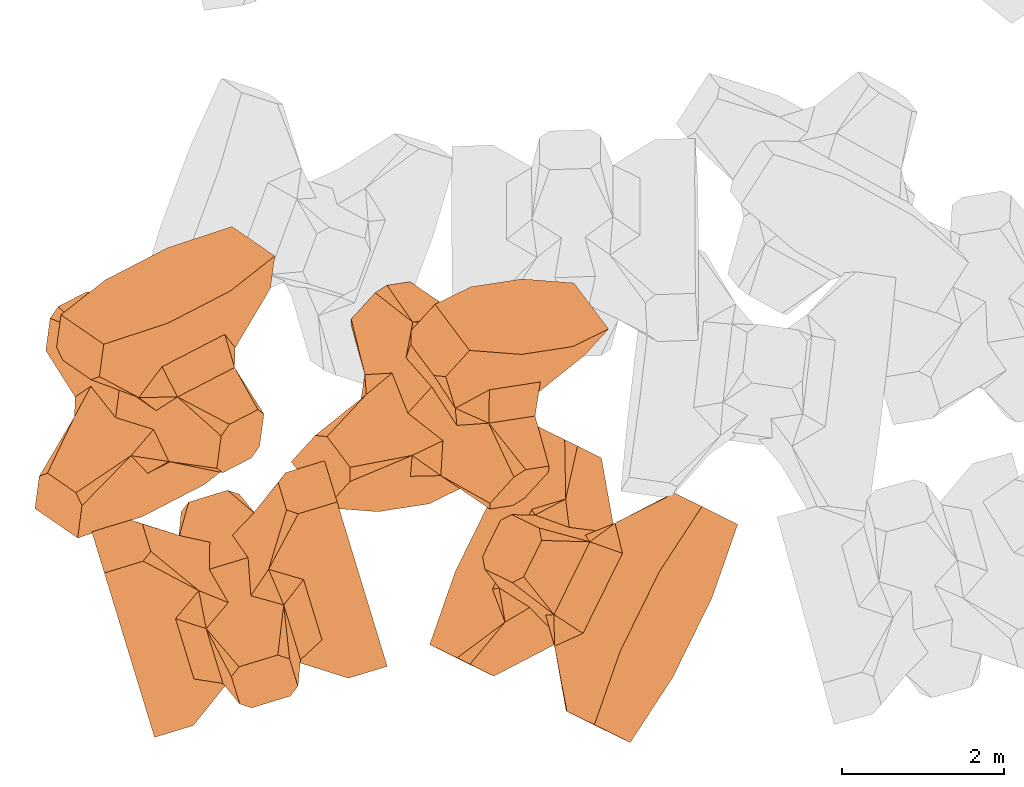
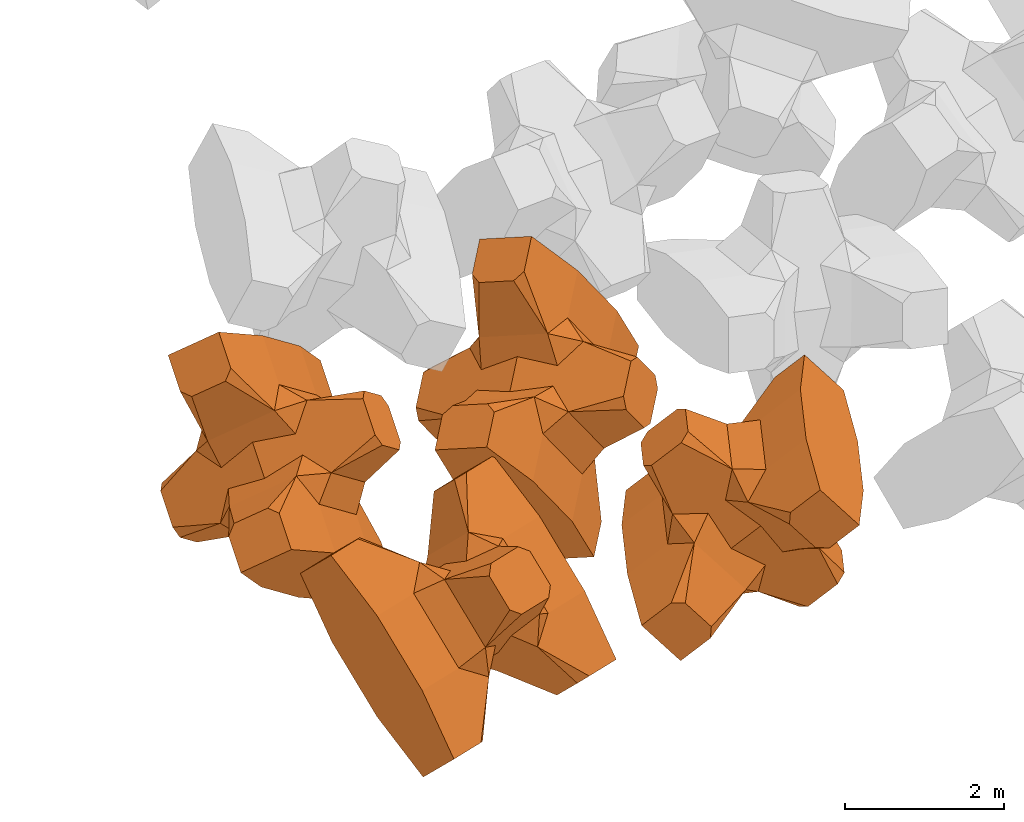
# One storey, part 1 of 17: 4 civil elements.
"""IFC4 building model written with IfcOpenShell, lengths in metres."""

from ifc_helpers import new_model, entity, si_unit, converted_unit, frame, origin_with_axes, origin_2d_with_axis, place, context, subcontext, project, spatial, polygons, element, save


model = new_model("IFC4")

# Units and contexts
model_context = context("Model", 3, precision=1e-05, world=origin_with_axes())
plan_context = context("Plan", 2, precision=1e-05, world=origin_2d_with_axis())
body_context = subcontext(model_context, "Body", "Model", "MODEL_VIEW")
ifc_project = project(units=[si_unit("VOLUMEUNIT", "CUBIC_METRE"), si_unit("LENGTHUNIT", "METRE"), converted_unit("PLANEANGLEUNIT", "degree", entity("IfcReal", 0.0174532925199433), si_unit("PLANEANGLEUNIT", "RADIAN"), dimensions=[0, 0, 0, 0, 0, 0, 0]), si_unit("AREAUNIT", "SQUARE_METRE")], contexts=[model_context, plan_context])

# Site, building, storey
site_placement = place(None, origin_with_axes())
site = spatial("IfcSite", under=ifc_project, at=site_placement)
building_placement = place(site_placement, origin_with_axes())
building = spatial("IfcBuilding", under=site, at=building_placement, Name="Building")
storey_placement = place(building_placement, origin_with_axes())
storey = spatial("IfcBuildingStorey", under=building, at=storey_placement, Name="Storey")

# Civil elements
civil_element_1_placement = place(storey_placement, frame((1.73069775104523, -20.6224308013916, 2.37295413017273), z_axis=(-0.206634434971923, 0.67694599384615, -0.706432114006351), x_axis=(-0.206210112575733, 0.675665398113698, 0.707780798880107)))
element("IfcCivilElement", 1, at=civil_element_1_placement, inside=storey, ObjectType="IfcCivilElementType", context=body_context, shape_type="Tessellation", body=[
    polygons([(0.50000011920929, 0.500000059604645, 0.821428656578064), (0.374999821186066, 0.249999940395355, 1.5), (0.550000011920929, 0.145680621266365, 0.550000071525574), (0.374999821186066, -0.250000029802322, 1.5), (0.651315808296204, -0.250000029802322, 1.45970545872842e-07), (0.651315808296204, 0.249999940395355, 1.45970545872842e-07), (0.550000011920929, -0.145680695772171, 0.550000071525574), (0.50000011920929, -0.500000059604645, 0.821428656578064), (-0.25, 0.374999791383743, 1.5), (0.249999970197678, 0.374999791383743, 1.5), (-0.500000059604645, 0.500000059604645, 0.821428656578064), (-0.550000011920929, 0.824999988079071, 0.550000071525574), (0.550000011920929, 0.824999988079071, 0.550000071525574), (-0.550000011920929, 1.5, 0.550000071525574), (0.550000011920929, 1.5, 0.550000071525574), (-0.25, -0.375, 1.5), (0.249999970197678, -0.375, 1.5), (-0.374999970197678, -0.250000029802322, 1.5), (-0.374999970197678, 0.249999940395355, 1.5), (1.5, 0.87499988079071, -0.249999806284904), (1.5, 0.87499988079071, 0.25000011920929), (0.845557510852814, 0.449999898672104, -0.495555102825165), (0.845557510852814, 0.449999898672104, 0.495555102825165), (1.5, 1.5, -0.374999791383743), (1.5, 1.5, 0.374999940395355), (1.5, 1.0, -0.374999791383743), (1.5, 1.0, 0.374999940395355), (-1.5, 1.5, -0.374999791383743), (-1.5, 1.5, 0.374999940395355), (-0.550000011920929, 1.5, -0.54999977350235), (0.550000011920929, 1.5, -0.54999977350235), (0.550000011920929, 0.145680621266365, -0.54999977350235), (-0.500000059604645, -0.500000059604645, 0.821428656578064), (-0.550000011920929, -0.145680695772171, 0.550000071525574), (-0.651315808296204, 0.249999940395355, 1.45970545872842e-07), (-0.651315808296204, -0.250000029802322, 1.45970545872842e-07), (-0.550000011920929, 0.145680621266365, 0.550000071525574), (-1.5, 0.87499988079071, 0.25000011920929), (-1.5, 0.87499988079071, -0.249999806284904), (-0.845557391643524, 0.449999898672104, 0.495555102825165), (-0.845557391643524, 0.449999898672104, -0.495555102825165), (-1.5, 1.0, 0.374999940395355), (-1.5, 1.0, -0.374999791383743), (-0.550000011920929, 0.145680621266365, -0.54999977350235), (0.550000011920929, -0.825000107288361, 0.550000071525574), (-0.550000011920929, -0.825000107288361, 0.550000071525574), (0.550000011920929, -1.5, 0.550000071525574), (-0.550000011920929, -1.5, 0.550000071525574), (1.5, -0.875000059604645, 0.25000011920929), (1.5, -0.875000059604645, -0.249999806284904), (0.845557510852814, -0.450000137090683, 0.495555102825165), (0.845557510852814, -0.450000137090683, -0.495555102825165), (1.5, -1.5, 0.374999940395355), (1.5, -1.5, -0.374999791383743), (1.5, -1.00000011920929, 0.374999940395355), (1.5, -1.00000011920929, -0.374999791383743), (0.550000011920929, -1.5, -0.54999977350235), (-0.550000011920929, -1.5, -0.54999977350235), (-1.5, -1.5, -0.374999791383743), (-1.5, -1.5, 0.374999940395355), (0.550000011920929, -0.145680695772171, -0.54999977350235), (-1.5, -0.875000059604645, -0.249999806284904), (-1.5, -0.875000059604645, 0.25000011920929), (-0.845557391643524, -0.450000137090683, -0.495555102825165), (-0.845557391643524, -0.450000137090683, 0.495555102825165), (-1.5, -1.00000011920929, -0.374999791383743), (-1.5, -1.00000011920929, 0.374999940395355), (-0.550000011920929, -0.145680695772171, -0.54999977350235), (0.50000011920929, -0.500000059604645, -0.821428418159485), (0.374999821186066, -0.250000029802322, -1.49999976158142), (0.374999821186066, 0.249999940395355, -1.49999976158142), (0.50000011920929, 0.500000059604645, -0.821428418159485), (0.249999970197678, 0.374999791383743, -1.49999976158142), (-0.25, 0.374999791383743, -1.49999976158142), (-0.500000059604645, 0.500000059604645, -0.821428418159485), (0.550000011920929, 0.824999988079071, -0.54999977350235), (-0.550000011920929, 0.824999988079071, -0.54999977350235), (0.249999970197678, -0.375, -1.49999976158142), (-0.25, -0.375, -1.49999976158142), (-0.374999970197678, -0.250000029802322, -1.49999976158142), (-0.374999970197678, 0.249999940395355, -1.49999976158142), (-0.500000059604645, -0.500000059604645, -0.821428418159485), (-0.550000011920929, -0.825000107288361, -0.54999977350235), (0.550000011920929, -0.825000107288361, -0.54999977350235)], [[[1, 2, 3]], [[3, 2, 4]], [[5, 6, 7]], [[7, 6, 3]], [[7, 3, 8]], [[8, 3, 4]], [[9, 10, 11]], [[11, 10, 1]], [[12, 13, 14]], [[14, 13, 15]], [[16, 17, 18]], [[18, 17, 4]], [[18, 4, 19]], [[19, 4, 2]], [[19, 2, 9]], [[9, 2, 10]], [[20, 21, 22]], [[22, 21, 23]], [[24, 25, 26]], [[26, 25, 27]], [[26, 27, 20]], [[20, 27, 21]], [[23, 27, 13]], [[13, 27, 25]], [[13, 25, 15]], [[28, 29, 30]], [[30, 29, 14]], [[30, 14, 31]], [[31, 14, 15]], [[31, 15, 24]], [[24, 15, 25]], [[21, 27, 23]], [[2, 1, 10]], [[13, 12, 1]], [[1, 12, 11]], [[13, 1, 23]], [[32, 22, 6]], [[6, 22, 23]], [[6, 23, 3]], [[3, 23, 1]], [[33, 18, 34]], [[34, 18, 19]], [[35, 36, 37]], [[37, 36, 34]], [[37, 34, 11]], [[11, 34, 19]], [[38, 39, 40]], [[40, 39, 41]], [[29, 28, 42]], [[42, 28, 43]], [[42, 43, 38]], [[38, 43, 39]], [[14, 29, 12]], [[12, 29, 42]], [[12, 42, 40]], [[40, 42, 38]], [[9, 11, 19]], [[40, 11, 12]], [[37, 40, 35]], [[35, 40, 41]], [[35, 41, 44]], [[11, 40, 37]], [[17, 16, 8]], [[8, 16, 33]], [[45, 46, 47]], [[47, 46, 48]], [[49, 50, 51]], [[51, 50, 52]], [[53, 54, 55]], [[55, 54, 56]], [[55, 56, 49]], [[49, 56, 50]], [[47, 53, 45]], [[45, 53, 55]], [[45, 55, 51]], [[54, 53, 57]], [[57, 53, 47]], [[57, 47, 58]], [[58, 47, 48]], [[58, 48, 59]], [[59, 48, 60]], [[51, 55, 49]], [[17, 8, 4]], [[46, 45, 33]], [[33, 45, 8]], [[51, 8, 45]], [[7, 51, 5]], [[5, 51, 52]], [[5, 52, 61]], [[8, 51, 7]], [[62, 63, 64]], [[64, 63, 65]], [[59, 60, 66]], [[66, 60, 67]], [[66, 67, 62]], [[62, 67, 63]], [[65, 67, 46]], [[46, 67, 60]], [[46, 60, 48]], [[63, 67, 65]], [[18, 33, 16]], [[46, 33, 65]], [[68, 64, 36]], [[36, 64, 65]], [[36, 65, 34]], [[34, 65, 33]], [[69, 70, 61]], [[61, 70, 71]], [[6, 5, 32]], [[32, 5, 61]], [[32, 61, 72]], [[72, 61, 71]], [[73, 74, 72]], [[72, 74, 75]], [[76, 77, 31]], [[31, 77, 30]], [[78, 79, 70]], [[70, 79, 80]], [[70, 80, 71]], [[71, 80, 81]], [[71, 81, 73]], [[73, 81, 74]], [[31, 24, 76]], [[76, 24, 26]], [[76, 26, 22]], [[22, 26, 20]], [[73, 72, 71]], [[77, 76, 75]], [[75, 76, 72]], [[22, 72, 76]], [[72, 22, 32]], [[75, 81, 44]], [[44, 81, 80]], [[36, 35, 68]], [[68, 35, 44]], [[68, 44, 82]], [[82, 44, 80]], [[41, 43, 77]], [[77, 43, 28]], [[77, 28, 30]], [[39, 43, 41]], [[81, 75, 74]], [[77, 75, 41]], [[44, 41, 75]], [[79, 78, 82]], [[82, 78, 69]], [[83, 84, 58]], [[58, 84, 57]], [[52, 56, 84]], [[84, 56, 54]], [[84, 54, 57]], [[50, 56, 52]], [[70, 69, 78]], [[84, 83, 69]], [[69, 83, 82]], [[84, 69, 52]], [[61, 52, 69]], [[58, 59, 83]], [[83, 59, 66]], [[83, 66, 64]], [[64, 66, 62]], [[79, 82, 80]], [[64, 82, 83]], [[82, 64, 68]]], closed=True),
])
civil_element_2_placement = place(storey_placement, frame((5.97362947463989, -20.4420146942139, 2.45005917549133), z_axis=(0.588767232763542, -0.294545025760441, -0.752725961704352), x_axis=(0.441944731320215, 0.897026445943436, -0.00533007846010986)))
element("IfcCivilElement", 2, at=civil_element_2_placement, inside=storey, ObjectType="IfcCivilElementType", context=body_context, shape_type="Tessellation", body=[
    polygons([(0.50000011920929, 0.500000059604645, 0.821428656578064), (0.374999821186066, 0.249999940395355, 1.5), (0.550000011920929, 0.145680621266365, 0.550000071525574), (0.374999821186066, -0.250000029802322, 1.5), (0.651315808296204, -0.250000029802322, 1.45970545872842e-07), (0.651315808296204, 0.249999940395355, 1.45970545872842e-07), (0.550000011920929, -0.145680695772171, 0.550000071525574), (0.50000011920929, -0.500000059604645, 0.821428656578064), (-0.25, 0.374999791383743, 1.5), (0.249999970197678, 0.374999791383743, 1.5), (-0.500000059604645, 0.500000059604645, 0.821428656578064), (-0.550000011920929, 0.824999988079071, 0.550000071525574), (0.550000011920929, 0.824999988079071, 0.550000071525574), (-0.550000011920929, 1.5, 0.550000071525574), (0.550000011920929, 1.5, 0.550000071525574), (-0.25, -0.375, 1.5), (0.249999970197678, -0.375, 1.5), (-0.374999970197678, -0.250000029802322, 1.5), (-0.374999970197678, 0.249999940395355, 1.5), (1.5, 0.87499988079071, -0.249999806284904), (1.5, 0.87499988079071, 0.25000011920929), (0.845557510852814, 0.449999898672104, -0.495555102825165), (0.845557510852814, 0.449999898672104, 0.495555102825165), (1.5, 1.5, -0.374999791383743), (1.5, 1.5, 0.374999940395355), (1.5, 1.0, -0.374999791383743), (1.5, 1.0, 0.374999940395355), (-1.5, 1.5, -0.374999791383743), (-1.5, 1.5, 0.374999940395355), (-0.550000011920929, 1.5, -0.54999977350235), (0.550000011920929, 1.5, -0.54999977350235), (0.550000011920929, 0.145680621266365, -0.54999977350235), (-0.500000059604645, -0.500000059604645, 0.821428656578064), (-0.550000011920929, -0.145680695772171, 0.550000071525574), (-0.651315808296204, 0.249999940395355, 1.45970545872842e-07), (-0.651315808296204, -0.250000029802322, 1.45970545872842e-07), (-0.550000011920929, 0.145680621266365, 0.550000071525574), (-1.5, 0.87499988079071, 0.25000011920929), (-1.5, 0.87499988079071, -0.249999806284904), (-0.845557391643524, 0.449999898672104, 0.495555102825165), (-0.845557391643524, 0.449999898672104, -0.495555102825165), (-1.5, 1.0, 0.374999940395355), (-1.5, 1.0, -0.374999791383743), (-0.550000011920929, 0.145680621266365, -0.54999977350235), (0.550000011920929, -0.825000107288361, 0.550000071525574), (-0.550000011920929, -0.825000107288361, 0.550000071525574), (0.550000011920929, -1.5, 0.550000071525574), (-0.550000011920929, -1.5, 0.550000071525574), (1.5, -0.875000059604645, 0.25000011920929), (1.5, -0.875000059604645, -0.249999806284904), (0.845557510852814, -0.450000137090683, 0.495555102825165), (0.845557510852814, -0.450000137090683, -0.495555102825165), (1.5, -1.5, 0.374999940395355), (1.5, -1.5, -0.374999791383743), (1.5, -1.00000011920929, 0.374999940395355), (1.5, -1.00000011920929, -0.374999791383743), (0.550000011920929, -1.5, -0.54999977350235), (-0.550000011920929, -1.5, -0.54999977350235), (-1.5, -1.5, -0.374999791383743), (-1.5, -1.5, 0.374999940395355), (0.550000011920929, -0.145680695772171, -0.54999977350235), (-1.5, -0.875000059604645, -0.249999806284904), (-1.5, -0.875000059604645, 0.25000011920929), (-0.845557391643524, -0.450000137090683, -0.495555102825165), (-0.845557391643524, -0.450000137090683, 0.495555102825165), (-1.5, -1.00000011920929, -0.374999791383743), (-1.5, -1.00000011920929, 0.374999940395355), (-0.550000011920929, -0.145680695772171, -0.54999977350235), (0.50000011920929, -0.500000059604645, -0.821428418159485), (0.374999821186066, -0.250000029802322, -1.49999976158142), (0.374999821186066, 0.249999940395355, -1.49999976158142), (0.50000011920929, 0.500000059604645, -0.821428418159485), (0.249999970197678, 0.374999791383743, -1.49999976158142), (-0.25, 0.374999791383743, -1.49999976158142), (-0.500000059604645, 0.500000059604645, -0.821428418159485), (0.550000011920929, 0.824999988079071, -0.54999977350235), (-0.550000011920929, 0.824999988079071, -0.54999977350235), (0.249999970197678, -0.375, -1.49999976158142), (-0.25, -0.375, -1.49999976158142), (-0.374999970197678, -0.250000029802322, -1.49999976158142), (-0.374999970197678, 0.249999940395355, -1.49999976158142), (-0.500000059604645, -0.500000059604645, -0.821428418159485), (-0.550000011920929, -0.825000107288361, -0.54999977350235), (0.550000011920929, -0.825000107288361, -0.54999977350235)], [[[1, 2, 3]], [[3, 2, 4]], [[5, 6, 7]], [[7, 6, 3]], [[7, 3, 8]], [[8, 3, 4]], [[9, 10, 11]], [[11, 10, 1]], [[12, 13, 14]], [[14, 13, 15]], [[16, 17, 18]], [[18, 17, 4]], [[18, 4, 19]], [[19, 4, 2]], [[19, 2, 9]], [[9, 2, 10]], [[20, 21, 22]], [[22, 21, 23]], [[24, 25, 26]], [[26, 25, 27]], [[26, 27, 20]], [[20, 27, 21]], [[23, 27, 13]], [[13, 27, 25]], [[13, 25, 15]], [[28, 29, 30]], [[30, 29, 14]], [[30, 14, 31]], [[31, 14, 15]], [[31, 15, 24]], [[24, 15, 25]], [[21, 27, 23]], [[2, 1, 10]], [[13, 12, 1]], [[1, 12, 11]], [[13, 1, 23]], [[32, 22, 6]], [[6, 22, 23]], [[6, 23, 3]], [[3, 23, 1]], [[33, 18, 34]], [[34, 18, 19]], [[35, 36, 37]], [[37, 36, 34]], [[37, 34, 11]], [[11, 34, 19]], [[38, 39, 40]], [[40, 39, 41]], [[29, 28, 42]], [[42, 28, 43]], [[42, 43, 38]], [[38, 43, 39]], [[14, 29, 12]], [[12, 29, 42]], [[12, 42, 40]], [[40, 42, 38]], [[9, 11, 19]], [[40, 11, 12]], [[37, 40, 35]], [[35, 40, 41]], [[35, 41, 44]], [[11, 40, 37]], [[17, 16, 8]], [[8, 16, 33]], [[45, 46, 47]], [[47, 46, 48]], [[49, 50, 51]], [[51, 50, 52]], [[53, 54, 55]], [[55, 54, 56]], [[55, 56, 49]], [[49, 56, 50]], [[47, 53, 45]], [[45, 53, 55]], [[45, 55, 51]], [[54, 53, 57]], [[57, 53, 47]], [[57, 47, 58]], [[58, 47, 48]], [[58, 48, 59]], [[59, 48, 60]], [[51, 55, 49]], [[17, 8, 4]], [[46, 45, 33]], [[33, 45, 8]], [[51, 8, 45]], [[7, 51, 5]], [[5, 51, 52]], [[5, 52, 61]], [[8, 51, 7]], [[62, 63, 64]], [[64, 63, 65]], [[59, 60, 66]], [[66, 60, 67]], [[66, 67, 62]], [[62, 67, 63]], [[65, 67, 46]], [[46, 67, 60]], [[46, 60, 48]], [[63, 67, 65]], [[18, 33, 16]], [[46, 33, 65]], [[68, 64, 36]], [[36, 64, 65]], [[36, 65, 34]], [[34, 65, 33]], [[69, 70, 61]], [[61, 70, 71]], [[6, 5, 32]], [[32, 5, 61]], [[32, 61, 72]], [[72, 61, 71]], [[73, 74, 72]], [[72, 74, 75]], [[76, 77, 31]], [[31, 77, 30]], [[78, 79, 70]], [[70, 79, 80]], [[70, 80, 71]], [[71, 80, 81]], [[71, 81, 73]], [[73, 81, 74]], [[31, 24, 76]], [[76, 24, 26]], [[76, 26, 22]], [[22, 26, 20]], [[73, 72, 71]], [[77, 76, 75]], [[75, 76, 72]], [[22, 72, 76]], [[72, 22, 32]], [[75, 81, 44]], [[44, 81, 80]], [[36, 35, 68]], [[68, 35, 44]], [[68, 44, 82]], [[82, 44, 80]], [[41, 43, 77]], [[77, 43, 28]], [[77, 28, 30]], [[39, 43, 41]], [[81, 75, 74]], [[77, 75, 41]], [[44, 41, 75]], [[79, 78, 82]], [[82, 78, 69]], [[83, 84, 58]], [[58, 84, 57]], [[52, 56, 84]], [[84, 56, 54]], [[84, 54, 57]], [[50, 56, 52]], [[70, 69, 78]], [[84, 83, 69]], [[69, 83, 82]], [[84, 69, 52]], [[61, 52, 69]], [[58, 59, 83]], [[83, 59, 66]], [[83, 66, 64]], [[64, 66, 62]], [[79, 82, 80]], [[64, 82, 83]], [[82, 64, 68]]], closed=True),
])
civil_element_3_placement = place(storey_placement, frame((4.32435464859009, -18.1105155944824, 3.30373954772949), z_axis=(-0.570313873471634, 0.757760468552897, -0.317082257504696), x_axis=(-0.571003902455056, -0.0882218536965022, 0.816193266274263)))
element("IfcCivilElement", 3, at=civil_element_3_placement, inside=storey, ObjectType="IfcCivilElementType", context=body_context, shape_type="Tessellation", body=[
    polygons([(0.500000059604645, 0.500000059604645, 0.821428596973419), (0.374999791383743, 0.249999940395355, 1.49999988079071), (0.549999952316284, 0.145680621266365, 0.550000011920929), (0.374999791383743, -0.250000029802322, 1.49999988079071), (0.651315748691559, -0.250000029802322, 1.45970531661987e-07), (0.651315748691559, 0.249999940395355, 1.45970531661987e-07), (0.549999952316284, -0.145680695772171, 0.550000011920929), (0.500000059604645, -0.500000059604645, 0.821428596973419), (-0.249999970197678, 0.374999791383743, 1.49999988079071), (0.249999940395355, 0.374999791383743, 1.49999988079071), (-0.5, 0.500000059604645, 0.821428596973419), (-0.549999952316284, 0.824999988079071, 0.550000011920929), (0.549999952316284, 0.824999988079071, 0.550000011920929), (-0.549999952316284, 1.5, 0.550000011920929), (0.549999952316284, 1.5, 0.550000011920929), (-0.249999970197678, -0.375, 1.49999988079071), (0.249999940395355, -0.375, 1.49999988079071), (-0.374999940395355, -0.250000029802322, 1.49999988079071), (-0.374999940395355, 0.249999940395355, 1.49999988079071), (1.49999988079071, 0.87499988079071, -0.249999791383743), (1.49999988079071, 0.87499988079071, 0.250000089406967), (0.845557451248169, 0.449999898672104, -0.495555073022842), (0.845557451248169, 0.449999898672104, 0.495555073022842), (1.49999988079071, 1.5, -0.374999761581421), (1.49999988079071, 1.5, 0.374999910593033), (1.49999988079071, 1.0, -0.374999761581421), (1.49999988079071, 1.0, 0.374999910593033), (-1.49999988079071, 1.5, -0.374999761581421), (-1.49999988079071, 1.5, 0.374999910593033), (-0.549999952316284, 1.5, -0.549999713897705), (0.549999952316284, 1.5, -0.549999713897705), (0.549999952316284, 0.145680621266365, -0.549999713897705), (-0.5, -0.500000059604645, 0.821428596973419), (-0.549999952316284, -0.145680695772171, 0.550000011920929), (-0.651315748691559, 0.249999940395355, 1.45970531661987e-07), (-0.651315748691559, -0.250000029802322, 1.45970531661987e-07), (-0.549999952316284, 0.145680621266365, 0.550000011920929), (-1.49999988079071, 0.87499988079071, 0.250000089406967), (-1.49999988079071, 0.87499988079071, -0.249999791383743), (-0.845557332038879, 0.449999898672104, 0.495555073022842), (-0.845557332038879, 0.449999898672104, -0.495555073022842), (-1.49999988079071, 1.0, 0.374999910593033), (-1.49999988079071, 1.0, -0.374999761581421), (-0.549999952316284, 0.145680621266365, -0.549999713897705), (0.549999952316284, -0.825000107288361, 0.550000011920929), (-0.549999952316284, -0.825000107288361, 0.550000011920929), (0.549999952316284, -1.5, 0.550000011920929), (-0.549999952316284, -1.5, 0.550000011920929), (1.49999988079071, -0.875000059604645, 0.250000089406967), (1.49999988079071, -0.875000059604645, -0.249999791383743), (0.845557451248169, -0.450000137090683, 0.495555073022842), (0.845557451248169, -0.450000137090683, -0.495555073022842), (1.49999988079071, -1.5, 0.374999910593033), (1.49999988079071, -1.5, -0.374999761581421), (1.49999988079071, -1.00000011920929, 0.374999910593033), (1.49999988079071, -1.00000011920929, -0.374999761581421), (0.549999952316284, -1.5, -0.549999713897705), (-0.549999952316284, -1.5, -0.549999713897705), (-1.49999988079071, -1.5, -0.374999761581421), (-1.49999988079071, -1.5, 0.374999910593033), (0.549999952316284, -0.145680695772171, -0.549999713897705), (-1.49999988079071, -0.875000059604645, -0.249999791383743), (-1.49999988079071, -0.875000059604645, 0.250000089406967), (-0.845557332038879, -0.450000137090683, -0.495555073022842), (-0.845557332038879, -0.450000137090683, 0.495555073022842), (-1.49999988079071, -1.00000011920929, -0.374999761581421), (-1.49999988079071, -1.00000011920929, 0.374999910593033), (-0.549999952316284, -0.145680695772171, -0.549999713897705), (0.500000059604645, -0.500000059604645, -0.82142835855484), (0.374999791383743, -0.250000029802322, -1.49999964237213), (0.374999791383743, 0.249999940395355, -1.49999964237213), (0.500000059604645, 0.500000059604645, -0.82142835855484), (0.249999940395355, 0.374999791383743, -1.49999964237213), (-0.249999970197678, 0.374999791383743, -1.49999964237213), (-0.5, 0.500000059604645, -0.82142835855484), (0.549999952316284, 0.824999988079071, -0.549999713897705), (-0.549999952316284, 0.824999988079071, -0.549999713897705), (0.249999940395355, -0.375, -1.49999964237213), (-0.249999970197678, -0.375, -1.49999964237213), (-0.374999940395355, -0.250000029802322, -1.49999964237213), (-0.374999940395355, 0.249999940395355, -1.49999964237213), (-0.5, -0.500000059604645, -0.82142835855484), (-0.549999952316284, -0.825000107288361, -0.549999713897705), (0.549999952316284, -0.825000107288361, -0.549999713897705)], [[[1, 2, 3]], [[3, 2, 4]], [[5, 6, 7]], [[7, 6, 3]], [[7, 3, 8]], [[8, 3, 4]], [[9, 10, 11]], [[11, 10, 1]], [[12, 13, 14]], [[14, 13, 15]], [[16, 17, 18]], [[18, 17, 4]], [[18, 4, 19]], [[19, 4, 2]], [[19, 2, 9]], [[9, 2, 10]], [[20, 21, 22]], [[22, 21, 23]], [[24, 25, 26]], [[26, 25, 27]], [[26, 27, 20]], [[20, 27, 21]], [[23, 27, 13]], [[13, 27, 25]], [[13, 25, 15]], [[28, 29, 30]], [[30, 29, 14]], [[30, 14, 31]], [[31, 14, 15]], [[31, 15, 24]], [[24, 15, 25]], [[21, 27, 23]], [[2, 1, 10]], [[13, 12, 1]], [[1, 12, 11]], [[13, 1, 23]], [[32, 22, 6]], [[6, 22, 23]], [[6, 23, 3]], [[3, 23, 1]], [[33, 18, 34]], [[34, 18, 19]], [[35, 36, 37]], [[37, 36, 34]], [[37, 34, 11]], [[11, 34, 19]], [[38, 39, 40]], [[40, 39, 41]], [[29, 28, 42]], [[42, 28, 43]], [[42, 43, 38]], [[38, 43, 39]], [[14, 29, 12]], [[12, 29, 42]], [[12, 42, 40]], [[40, 42, 38]], [[9, 11, 19]], [[40, 11, 12]], [[37, 40, 35]], [[35, 40, 41]], [[35, 41, 44]], [[11, 40, 37]], [[17, 16, 8]], [[8, 16, 33]], [[45, 46, 47]], [[47, 46, 48]], [[49, 50, 51]], [[51, 50, 52]], [[53, 54, 55]], [[55, 54, 56]], [[55, 56, 49]], [[49, 56, 50]], [[47, 53, 45]], [[45, 53, 55]], [[45, 55, 51]], [[54, 53, 57]], [[57, 53, 47]], [[57, 47, 58]], [[58, 47, 48]], [[58, 48, 59]], [[59, 48, 60]], [[51, 55, 49]], [[17, 8, 4]], [[46, 45, 33]], [[33, 45, 8]], [[51, 8, 45]], [[7, 51, 5]], [[5, 51, 52]], [[5, 52, 61]], [[8, 51, 7]], [[62, 63, 64]], [[64, 63, 65]], [[59, 60, 66]], [[66, 60, 67]], [[66, 67, 62]], [[62, 67, 63]], [[65, 67, 46]], [[46, 67, 60]], [[46, 60, 48]], [[63, 67, 65]], [[18, 33, 16]], [[46, 33, 65]], [[68, 64, 36]], [[36, 64, 65]], [[36, 65, 34]], [[34, 65, 33]], [[69, 70, 61]], [[61, 70, 71]], [[6, 5, 32]], [[32, 5, 61]], [[32, 61, 72]], [[72, 61, 71]], [[73, 74, 72]], [[72, 74, 75]], [[76, 77, 31]], [[31, 77, 30]], [[78, 79, 70]], [[70, 79, 80]], [[70, 80, 71]], [[71, 80, 81]], [[71, 81, 73]], [[73, 81, 74]], [[31, 24, 76]], [[76, 24, 26]], [[76, 26, 22]], [[22, 26, 20]], [[73, 72, 71]], [[77, 76, 75]], [[75, 76, 72]], [[22, 72, 76]], [[72, 22, 32]], [[75, 81, 44]], [[44, 81, 80]], [[36, 35, 68]], [[68, 35, 44]], [[68, 44, 82]], [[82, 44, 80]], [[41, 43, 77]], [[77, 43, 28]], [[77, 28, 30]], [[39, 43, 41]], [[81, 75, 74]], [[77, 75, 41]], [[44, 41, 75]], [[79, 78, 82]], [[82, 78, 69]], [[83, 84, 58]], [[58, 84, 57]], [[52, 56, 84]], [[84, 56, 54]], [[84, 54, 57]], [[50, 56, 52]], [[70, 69, 78]], [[84, 83, 69]], [[69, 83, 82]], [[84, 69, 52]], [[61, 52, 69]], [[58, 59, 83]], [[83, 59, 66]], [[83, 66, 64]], [[64, 66, 62]], [[79, 82, 80]], [[64, 82, 83]], [[82, 64, 68]]], closed=True),
])
civil_element_4_placement = place(storey_placement, frame((0.68681800365448, -17.9491329193115, 3.42499995231628), z_axis=(-0.702970269595541, 0.484304966783774, -0.52084690573463), x_axis=(-0.7031185618811, -0.363020658071088, 0.611424803023141)))
element("IfcCivilElement", 4, at=civil_element_4_placement, inside=storey, ObjectType="IfcCivilElementType", context=body_context, shape_type="Tessellation", body=[
    polygons([(0.500001966953278, 0.500000059604645, 0.821428835391998), (0.375001221895218, 0.249999940395355, 1.50000035762787), (0.550002038478851, 0.145680621266365, 0.550000190734863), (0.375001221895218, -0.250000029802322, 1.50000035762787), (0.651318252086639, -0.250000029802322, 1.45970574294552e-07), (0.651318252086639, 0.249999940395355, 1.45970574294552e-07), (0.550002038478851, -0.145680695772171, 0.550000190734863), (0.500001966953278, -0.500000059604645, 0.821428835391998), (-0.250000923871994, 0.374999791383743, 1.50000035762787), (0.250000894069672, 0.374999791383743, 1.50000035762787), (-0.500001907348633, 0.500000059604645, 0.821428835391998), (-0.550002038478851, 0.824999988079071, 0.550000190734863), (0.550002038478851, 0.824999988079071, 0.550000190734863), (-0.550002038478851, 1.5, 0.550000190734863), (0.550002038478851, 1.5, 0.550000190734863), (-0.250000923871994, -0.375, 1.50000035762787), (0.250000894069672, -0.375, 1.50000035762787), (-0.37500137090683, -0.250000029802322, 1.50000035762787), (-0.37500137090683, 0.249999940395355, 1.50000035762787), (1.50000560283661, 0.87499988079071, -0.249999865889549), (1.50000560283661, 0.87499988079071, 0.250000149011612), (0.845560669898987, 0.449999898672104, -0.495555222034454), (0.845560669898987, 0.449999898672104, 0.495555222034454), (1.50000560283661, 1.5, -0.374999850988388), (1.50000560283661, 1.5, 0.375), (1.50000560283661, 1.0, -0.374999850988388), (1.50000560283661, 1.0, 0.375), (-1.50000560283661, 1.5, -0.374999850988388), (-1.50000560283661, 1.5, 0.375), (-0.550002038478851, 1.5, -0.549999892711639), (0.550002038478851, 1.5, -0.549999892711639), (0.550002038478851, 0.145680621266365, -0.549999892711639), (-0.500001907348633, -0.500000059604645, 0.821428835391998), (-0.550002038478851, -0.145680695772171, 0.550000190734863), (-0.651318252086639, 0.249999940395355, 1.45970574294552e-07), (-0.651318252086639, -0.250000029802322, 1.45970574294552e-07), (-0.550002038478851, 0.145680621266365, 0.550000190734863), (-1.50000560283661, 0.87499988079071, 0.250000149011612), (-1.50000560283661, 0.87499988079071, -0.249999865889549), (-0.845560491085052, 0.449999898672104, 0.495555222034454), (-0.845560491085052, 0.449999898672104, -0.495555222034454), (-1.50000560283661, 1.0, 0.375), (-1.50000560283661, 1.0, -0.374999850988388), (-0.550002038478851, 0.145680621266365, -0.549999892711639), (0.550002038478851, -0.825000107288361, 0.550000190734863), (-0.550002038478851, -0.825000107288361, 0.550000190734863), (0.550002038478851, -1.5, 0.550000190734863), (-0.550002038478851, -1.5, 0.550000190734863), (1.50000560283661, -0.875000059604645, 0.250000149011612), (1.50000560283661, -0.875000059604645, -0.249999865889549), (0.845560669898987, -0.450000137090683, 0.495555222034454), (0.845560669898987, -0.450000137090683, -0.495555222034454), (1.50000560283661, -1.5, 0.375), (1.50000560283661, -1.5, -0.374999850988388), (1.50000560283661, -1.00000011920929, 0.375), (1.50000560283661, -1.00000011920929, -0.374999850988388), (0.550002038478851, -1.5, -0.549999892711639), (-0.550002038478851, -1.5, -0.549999892711639), (-1.50000560283661, -1.5, -0.374999850988388), (-1.50000560283661, -1.5, 0.375), (0.550002038478851, -0.145680695772171, -0.549999892711639), (-1.50000560283661, -0.875000059604645, -0.249999865889549), (-1.50000560283661, -0.875000059604645, 0.250000149011612), (-0.845560491085052, -0.450000137090683, -0.495555222034454), (-0.845560491085052, -0.450000137090683, 0.495555222034454), (-1.50000560283661, -1.00000011920929, -0.374999850988388), (-1.50000560283661, -1.00000011920929, 0.375), (-0.550002038478851, -0.145680695772171, -0.549999892711639), (0.500001966953278, -0.500000059604645, -0.821428596973419), (0.375001221895218, -0.250000029802322, -1.5), (0.375001221895218, 0.249999940395355, -1.5), (0.500001966953278, 0.500000059604645, -0.821428596973419), (0.250000894069672, 0.374999791383743, -1.5), (-0.250000923871994, 0.374999791383743, -1.5), (-0.500001907348633, 0.500000059604645, -0.821428596973419), (0.550002038478851, 0.824999988079071, -0.549999892711639), (-0.550002038478851, 0.824999988079071, -0.549999892711639), (0.250000894069672, -0.375, -1.5), (-0.250000923871994, -0.375, -1.5), (-0.37500137090683, -0.250000029802322, -1.5), (-0.37500137090683, 0.249999940395355, -1.5), (-0.500001907348633, -0.500000059604645, -0.821428596973419), (-0.550002038478851, -0.825000107288361, -0.549999892711639), (0.550002038478851, -0.825000107288361, -0.549999892711639)], [[[1, 2, 3]], [[3, 2, 4]], [[5, 6, 7]], [[7, 6, 3]], [[7, 3, 8]], [[8, 3, 4]], [[9, 10, 11]], [[11, 10, 1]], [[12, 13, 14]], [[14, 13, 15]], [[16, 17, 18]], [[18, 17, 4]], [[18, 4, 19]], [[19, 4, 2]], [[19, 2, 9]], [[9, 2, 10]], [[20, 21, 22]], [[22, 21, 23]], [[24, 25, 26]], [[26, 25, 27]], [[26, 27, 20]], [[20, 27, 21]], [[23, 27, 13]], [[13, 27, 25]], [[13, 25, 15]], [[28, 29, 30]], [[30, 29, 14]], [[30, 14, 31]], [[31, 14, 15]], [[31, 15, 24]], [[24, 15, 25]], [[21, 27, 23]], [[2, 1, 10]], [[13, 12, 1]], [[1, 12, 11]], [[13, 1, 23]], [[32, 22, 6]], [[6, 22, 23]], [[6, 23, 3]], [[3, 23, 1]], [[33, 18, 34]], [[34, 18, 19]], [[35, 36, 37]], [[37, 36, 34]], [[37, 34, 11]], [[11, 34, 19]], [[38, 39, 40]], [[40, 39, 41]], [[29, 28, 42]], [[42, 28, 43]], [[42, 43, 38]], [[38, 43, 39]], [[14, 29, 12]], [[12, 29, 42]], [[12, 42, 40]], [[40, 42, 38]], [[9, 11, 19]], [[40, 11, 12]], [[37, 40, 35]], [[35, 40, 41]], [[35, 41, 44]], [[11, 40, 37]], [[17, 16, 8]], [[8, 16, 33]], [[45, 46, 47]], [[47, 46, 48]], [[49, 50, 51]], [[51, 50, 52]], [[53, 54, 55]], [[55, 54, 56]], [[55, 56, 49]], [[49, 56, 50]], [[47, 53, 45]], [[45, 53, 55]], [[45, 55, 51]], [[54, 53, 57]], [[57, 53, 47]], [[57, 47, 58]], [[58, 47, 48]], [[58, 48, 59]], [[59, 48, 60]], [[51, 55, 49]], [[17, 8, 4]], [[46, 45, 33]], [[33, 45, 8]], [[51, 8, 45]], [[7, 51, 5]], [[5, 51, 52]], [[5, 52, 61]], [[8, 51, 7]], [[62, 63, 64]], [[64, 63, 65]], [[59, 60, 66]], [[66, 60, 67]], [[66, 67, 62]], [[62, 67, 63]], [[65, 67, 46]], [[46, 67, 60]], [[46, 60, 48]], [[63, 67, 65]], [[18, 33, 16]], [[46, 33, 65]], [[68, 64, 36]], [[36, 64, 65]], [[36, 65, 34]], [[34, 65, 33]], [[69, 70, 61]], [[61, 70, 71]], [[6, 5, 32]], [[32, 5, 61]], [[32, 61, 72]], [[72, 61, 71]], [[73, 74, 72]], [[72, 74, 75]], [[76, 77, 31]], [[31, 77, 30]], [[78, 79, 70]], [[70, 79, 80]], [[70, 80, 71]], [[71, 80, 81]], [[71, 81, 73]], [[73, 81, 74]], [[31, 24, 76]], [[76, 24, 26]], [[76, 26, 22]], [[22, 26, 20]], [[73, 72, 71]], [[77, 76, 75]], [[75, 76, 72]], [[22, 72, 76]], [[72, 22, 32]], [[75, 81, 44]], [[44, 81, 80]], [[36, 35, 68]], [[68, 35, 44]], [[68, 44, 82]], [[82, 44, 80]], [[41, 43, 77]], [[77, 43, 28]], [[77, 28, 30]], [[39, 43, 41]], [[81, 75, 74]], [[77, 75, 41]], [[44, 41, 75]], [[79, 78, 82]], [[82, 78, 69]], [[83, 84, 58]], [[58, 84, 57]], [[52, 56, 84]], [[84, 56, 54]], [[84, 54, 57]], [[50, 56, 52]], [[70, 69, 78]], [[84, 83, 69]], [[69, 83, 82]], [[84, 69, 52]], [[61, 52, 69]], [[58, 59, 83]], [[83, 59, 66]], [[83, 66, 64]], [[64, 66, 62]], [[79, 82, 80]], [[64, 82, 83]], [[82, 64, 68]]], closed=True),
])

save(model, "model.ifc")
